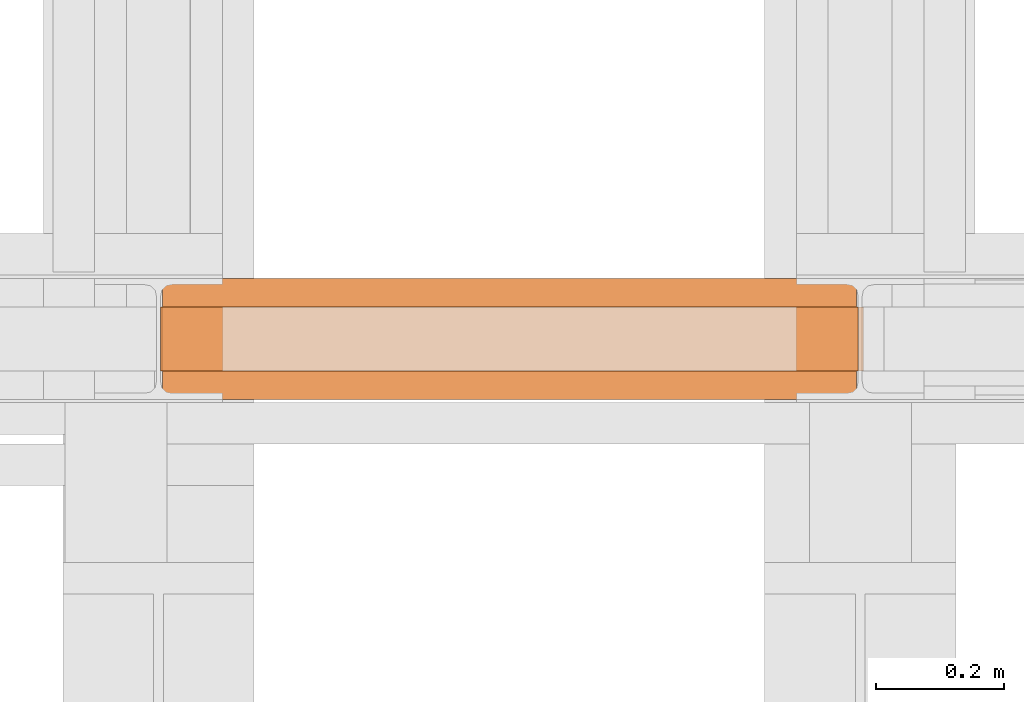
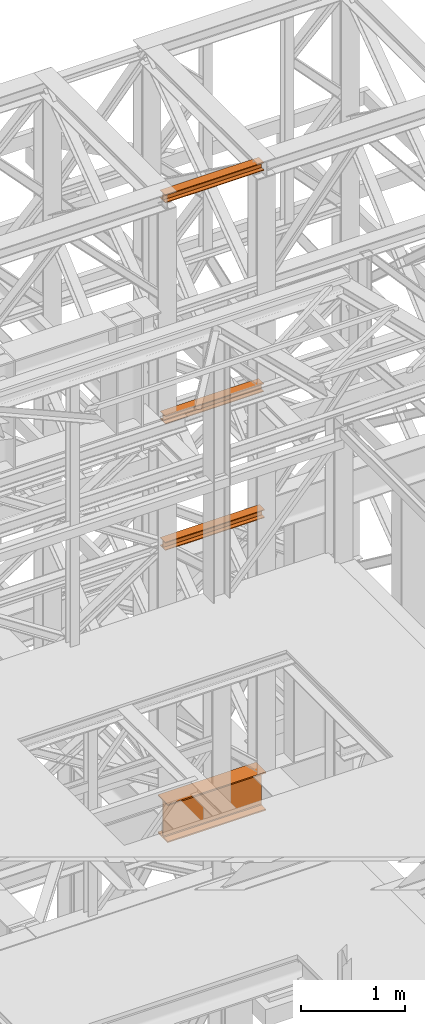
# One storey, part 152 of 208: 4 proxies.
"""IFC2X3 building model written with IfcOpenShell, lengths in millimetres."""

from ifc_helpers import new_model, entity, si_unit, converted_unit, frame, origin, origin_with_axes, place, context, subcontext, project, spatial, faceted_brep, element, save


model = new_model("IFC2X3")

# Units and contexts
model_context = context("Model", 3, precision=1e-05, world=origin())
plan_context = context("Plan", 3, precision=1e-05, world=origin())
body_context = subcontext(model_context, "Body", "Model", "MODEL_VIEW")
ifc_project = project(units=[si_unit("LENGTHUNIT", "METRE", prefix="MILLI"), converted_unit("PLANEANGLEUNIT", "DEGREE", entity("IfcPlaneAngleMeasure", 0.0174532925199433), si_unit("PLANEANGLEUNIT", "RADIAN"), dimensions=[0, 0, 0, 0, 0, 0, 0]), si_unit("AREAUNIT", "SQUARE_METRE"), si_unit("VOLUMEUNIT", "CUBIC_METRE")], contexts=[model_context, plan_context])

# Building, storey
building_placement = place(None, origin())
building = spatial("IfcBuilding", under=ifc_project, at=building_placement, CompositionType="COMPLEX")
storey_placement = place(building_placement, origin_with_axes())
storey = spatial("IfcBuildingStorey", under=building, at=storey_placement, Name="Geschoss", CompositionType="ELEMENT")

# Proxies
proxy_1_placement = place(storey_placement, frame((5499.254968580828, -16057.57439657637, 4834.989987483023), z_axis=(0.0, 0.0, 1.0), x_axis=(1.0, 0.0, 0.0)))
element("IfcBuildingElementProxy", 1, at=proxy_1_placement, inside=storey, context=body_context, shape_type="Brep", body=[
    faceted_brep([(1088.009999895696, 0.01000000000021828, 450.0100178813937), (1088.009999895696, 190.0100125169756, 450.0100178813937), (1088.009999895696, 190.0100125169756, 435.4100240564349), (1088.009999895696, 120.7100073045494, 435.4100091552737), (1088.009999895696, 109.841562265754, 433.2347078418734), (1088.009999895696, 101.8853126263621, 425.2784563398363), (1088.009999895696, 99.71000619068764, 414.4100113010409), (1088.009999895696, 99.71000619068764, 35.60999167919181), (1088.009999895696, 101.8853126263621, 24.74154664039634), (1088.009999895696, 109.841562265754, 16.78529513835929), (1088.009999895696, 120.7100073045494, 14.60999382495902), (1088.009999895696, 190.0100125169756, 14.60999382495902), (1088.009999895696, 190.0100125169756, 0.01000000000021828), (1088.009999895696, 0.01000000000021828, 0.01000000000021828), (1088.009999895696, 0.01000000000021828, 14.60999382495902), (1088.009999895696, 69.3100052124264, 14.60999382495902), (1088.009999895696, 80.17845025122188, 16.78529513835929), (1088.009999895696, 88.13469989061377, 24.74154664039634), (1088.009999895696, 90.3100063262882, 35.60999167919181), (1088.009999895696, 90.3100063262882, 414.4100113010409), (1088.009999895696, 88.13469989061377, 425.2784563398363), (1088.009999895696, 80.17845025122188, 433.2347078418734), (1088.009999895696, 69.3100052124264, 435.4100091552737), (1088.009999895696, 0.01000000000021828, 435.4100240564349), (1088.009999895696, 190.0100125169756, 450.0100178813937), (1088.009999895696, 0.01000000000021828, 450.0100178813937), (0.01000000000021828, 0.01000000000021828, 450.0100178813937), (0.01000000000021828, 190.0100125169756, 450.0100178813937), (1088.009999895696, 190.0100125169756, 435.4100240564349), (1088.009999895696, 190.0100125169756, 450.0100178813937), (0.01000000000021828, 190.0100125169756, 450.0100178813937), (0.01000000000021828, 190.0100125169756, 435.4100240564349), (1088.009999895696, 120.7100073045494, 435.4100091552737), (1088.009999895696, 190.0100125169756, 435.4100240564349), (0.01000000000021828, 190.0100125169756, 435.4100240564349), (0.01000000000021828, 120.7100073045494, 435.4100091552737), (1088.009999895696, 109.841562265754, 433.2347078418734), (1088.009999895696, 120.7100073045494, 435.4100091552737), (0.01000000000021828, 120.7100073045494, 435.4100091552737), (0.01000000000021828, 109.841562265754, 433.2347078418734), (1088.009999895696, 101.8853126263621, 425.2784563398363), (1088.009999895696, 109.841562265754, 433.2347078418734), (0.01000000000021828, 109.841562265754, 433.2347078418734), (0.01000000000021828, 101.8853126263621, 425.2784563398363), (1088.009999895696, 99.71000619068764, 414.4100113010409), (1088.009999895696, 101.8853126263621, 425.2784563398363), (0.01000000000021828, 101.8853126263621, 425.2784563398363), (0.01000000000021828, 99.71000619068764, 414.4100113010409), (1088.009999895696, 99.71000619068764, 35.60999167919181), (1088.009999895696, 99.71000619068764, 414.4100113010409), (0.01000000000021828, 99.71000619068764, 414.4100113010409), (0.01000000000021828, 99.71000619068764, 35.60999167919181), (1088.009999895696, 101.8853126263621, 24.74154664039634), (1088.009999895696, 99.71000619068764, 35.60999167919181), (0.01000000000021828, 99.71000619068764, 35.60999167919181), (0.01000000000021828, 101.8853126263621, 24.74154664039634), (1088.009999895696, 109.841562265754, 16.78529513835929), (1088.009999895696, 101.8853126263621, 24.74154664039634), (0.01000000000021828, 101.8853126263621, 24.74154664039634), (0.01000000000021828, 109.841562265754, 16.78529513835929), (1088.009999895696, 120.7100073045494, 14.60999382495902), (1088.009999895696, 109.841562265754, 16.78529513835929), (0.01000000000021828, 109.841562265754, 16.78529513835929), (0.01000000000021828, 120.7100073045494, 14.60999382495902), (1088.009999895696, 190.0100125169756, 14.60999382495902), (1088.009999895696, 120.7100073045494, 14.60999382495902), (0.01000000000021828, 120.7100073045494, 14.60999382495902), (0.01000000000021828, 190.0100125169756, 14.60999382495902), (1088.009999895696, 190.0100125169756, 0.01000000000021828), (1088.009999895696, 190.0100125169756, 14.60999382495902), (0.01000000000021828, 190.0100125169756, 14.60999382495902), (0.01000000000021828, 190.0100125169756, 0.01000000000021828), (1088.009999895696, 0.01000000000021828, 0.01000000000021828), (1088.009999895696, 190.0100125169756, 0.01000000000021828), (0.01000000000021828, 190.0100125169756, 0.01000000000021828), (0.01000000000021828, 0.01000000000021828, 0.01000000000021828), (1088.009999895696, 0.01000000000021828, 14.60999382495902), (1088.009999895696, 0.01000000000021828, 0.01000000000021828), (0.01000000000021828, 0.01000000000021828, 0.01000000000021828), (0.01000000000021828, 0.01000000000021828, 14.60999382495902), (1088.009999895696, 69.3100052124264, 14.60999382495902), (1088.009999895696, 0.01000000000021828, 14.60999382495902), (0.01000000000021828, 0.01000000000021828, 14.60999382495902), (0.01000000000021828, 69.3100052124264, 14.60999382495902), (1088.009999895696, 80.17845025122188, 16.78529513835929), (1088.009999895696, 69.3100052124264, 14.60999382495902), (0.01000000000021828, 69.3100052124264, 14.60999382495902), (0.01000000000021828, 80.17845025122188, 16.78529513835929), (1088.009999895696, 88.13469989061377, 24.74154664039634), (1088.009999895696, 80.17845025122188, 16.78529513835929), (0.01000000000021828, 80.17845025122188, 16.78529513835929), (0.01000000000021828, 88.13469989061377, 24.74154664039634), (1088.009999895696, 90.3100063262882, 35.60999167919181), (1088.009999895696, 88.13469989061377, 24.74154664039634), (0.01000000000021828, 88.13469989061377, 24.74154664039634), (0.01000000000021828, 90.3100063262882, 35.60999167919181), (1088.009999895696, 90.3100063262882, 414.4100113010409), (1088.009999895696, 90.3100063262882, 35.60999167919181), (0.01000000000021828, 90.3100063262882, 35.60999167919181), (0.01000000000021828, 90.3100063262882, 414.4100113010409), (1088.009999895696, 88.13469989061377, 425.2784563398363), (1088.009999895696, 90.3100063262882, 414.4100113010409), (0.01000000000021828, 90.3100063262882, 414.4100113010409), (0.01000000000021828, 88.13469989061377, 425.2784563398363), (1088.009999895696, 80.17845025122188, 433.2347078418734), (1088.009999895696, 88.13469989061377, 425.2784563398363), (0.01000000000021828, 88.13469989061377, 425.2784563398363), (0.01000000000021828, 80.17845025122188, 433.2347078418734), (1088.009999895696, 69.3100052124264, 435.4100091552737), (1088.009999895696, 80.17845025122188, 433.2347078418734), (0.01000000000021828, 80.17845025122188, 433.2347078418734), (0.01000000000021828, 69.3100052124264, 435.4100091552737), (1088.009999895696, 0.01000000000021828, 435.4100240564349), (1088.009999895696, 69.3100052124264, 435.4100091552737), (0.01000000000021828, 69.3100052124264, 435.4100091552737), (0.01000000000021828, 0.01000000000021828, 435.4100240564349), (1088.009999895696, 0.01000000000021828, 450.0100178813937), (1088.009999895696, 0.01000000000021828, 435.4100240564349), (0.01000000000021828, 0.01000000000021828, 435.4100240564349), (0.01000000000021828, 0.01000000000021828, 450.0100178813937), (0.01000000000021828, 0.01000000000021828, 450.0100178813937), (0.01000000000021828, 0.01000000000021828, 435.4100240564349), (0.01000000000021828, 69.3100052124264, 435.4100091552737), (0.01000000000021828, 80.17845025122188, 433.2347078418734), (0.01000000000021828, 88.13469989061377, 425.2784563398363), (0.01000000000021828, 90.3100063262882, 414.4100113010409), (0.01000000000021828, 90.3100063262882, 35.60999167919181), (0.01000000000021828, 88.13469989061377, 24.74154664039634), (0.01000000000021828, 80.17845025122188, 16.78529513835929), (0.01000000000021828, 69.3100052124264, 14.60999382495902), (0.01000000000021828, 0.01000000000021828, 14.60999382495902), (0.01000000000021828, 0.01000000000021828, 0.01000000000021828), (0.01000000000021828, 190.0100125169756, 0.01000000000021828), (0.01000000000021828, 190.0100125169756, 14.60999382495902), (0.01000000000021828, 120.7100073045494, 14.60999382495902), (0.01000000000021828, 109.841562265754, 16.78529513835929), (0.01000000000021828, 101.8853126263621, 24.74154664039634), (0.01000000000021828, 99.71000619068764, 35.60999167919181), (0.01000000000021828, 99.71000619068764, 414.4100113010409), (0.01000000000021828, 101.8853126263621, 425.2784563398363), (0.01000000000021828, 109.841562265754, 433.2347078418734), (0.01000000000021828, 120.7100073045494, 435.4100091552737), (0.01000000000021828, 190.0100125169756, 435.4100240564349), (0.01000000000021828, 190.0100125169756, 450.0100178813937)], [[[0, 1, 2, 3, 4, 5, 6, 7, 8, 9, 10, 11, 12, 13, 14, 15, 16, 17, 18, 19, 20, 21, 22, 23]], [[24, 25, 26, 27]], [[28, 29, 30, 31]], [[32, 33, 34, 35]], [[36, 37, 38, 39]], [[40, 41, 42, 43]], [[44, 45, 46, 47]], [[48, 49, 50, 51]], [[52, 53, 54, 55]], [[56, 57, 58, 59]], [[60, 61, 62, 63]], [[64, 65, 66, 67]], [[68, 69, 70, 71]], [[72, 73, 74, 75]], [[76, 77, 78, 79]], [[80, 81, 82, 83]], [[84, 85, 86, 87]], [[88, 89, 90, 91]], [[92, 93, 94, 95]], [[96, 97, 98, 99]], [[100, 101, 102, 103]], [[104, 105, 106, 107]], [[108, 109, 110, 111]], [[112, 113, 114, 115]], [[116, 117, 118, 119]], [[120, 121, 122, 123, 124, 125, 126, 127, 128, 129, 130, 131, 132, 133, 134, 135, 136, 137, 138, 139, 140, 141, 142, 143]]], orient=[[False], [False], [False], [False], [False], [False], [False], [False], [False], [False], [False], [False], [False], [False], [False], [False], [False], [False], [False], [False], [False], [False], [False], [False], [False], [False]]),
])
proxy_2_placement = place(storey_placement, frame((5498.369516902634, -16012.50587051043, 9710.10571322234), z_axis=(0.0, 0.0, 1.0), x_axis=(1.0, 0.0, 0.0)))
element("IfcBuildingElementProxy", 2, at=proxy_2_placement, inside=storey, context=body_context, shape_type="Brep", body=[
    faceted_brep([(1091.936120735611, 0.01000000000021828, 88.01000000000022), (1091.936120735611, 0.01000000000021828, 96.01000000000022), (1091.936120735611, 100.0100000000002, 96.01000000000022), (1091.936120735611, 100.0100000000002, 88.01000000000022), (1091.936120735611, 52.51000000000022, 88.01000000000022), (1091.936120735611, 52.51000000000022, 8.010000000000218), (1091.936120735611, 100.0100000000002, 8.010000000000218), (1091.936120735611, 100.0100000000002, 0.01000000000021828), (1091.936120735611, 0.01000000000021828, 0.01000000000021828), (1091.936120735611, 0.01000000000021828, 8.010000000000218), (1091.936120735611, 47.51000000000022, 8.010000000000218), (1091.936120735611, 47.51000000000022, 88.01000000000022), (1091.936120735611, 0.01000000000021828, 96.01000000000022), (1091.936120735611, 0.01000000000021828, 88.01000000000022), (0.009999999999308784, 0.01000000000385626, 88.01000000000022), (0.009999999999308784, 0.01000000000385626, 96.01000000000022), (1091.936120735611, 100.0100000000002, 96.01000000000022), (1091.936120735611, 0.01000000000021828, 96.01000000000022), (0.009999999999308784, 0.01000000000385626, 96.01000000000022), (0.009999999999308784, 100.0100000000039, 96.01000000000022), (1091.936120735611, 100.0100000000002, 88.01000000000022), (1091.936120735611, 100.0100000000002, 96.01000000000022), (0.009999999999308784, 100.0100000000039, 96.01000000000022), (0.009999999999308784, 100.0100000000039, 88.01000000000022), (1091.936120735611, 52.51000000000022, 88.01000000000022), (1091.936120735611, 100.0100000000002, 88.01000000000022), (0.009999999999308784, 100.0100000000039, 88.01000000000022), (0.009999999999308784, 52.51000000000386, 88.01000000000022), (1091.936120735611, 52.51000000000022, 8.010000000000218), (1091.936120735611, 52.51000000000022, 88.01000000000022), (0.009999999999308784, 52.51000000000386, 88.01000000000022), (0.009999999999308784, 52.51000000000386, 8.010000000000218), (1091.936120735611, 100.0100000000002, 8.010000000000218), (1091.936120735611, 52.51000000000022, 8.010000000000218), (0.009999999999308784, 52.51000000000386, 8.010000000000218), (0.009999999999308784, 100.0100000000039, 8.010000000000218), (1091.936120735611, 100.0100000000002, 0.01000000000021828), (1091.936120735611, 100.0100000000002, 8.010000000000218), (0.009999999999308784, 100.0100000000039, 8.010000000000218), (0.009999999999308784, 100.0100000000039, 0.01000000000021828), (1091.936120735611, 0.01000000000021828, 0.01000000000021828), (1091.936120735611, 100.0100000000002, 0.01000000000021828), (0.009999999999308784, 100.0100000000039, 0.01000000000021828), (0.009999999999308784, 0.01000000000385626, 0.01000000000021828), (1091.936120735611, 0.01000000000021828, 8.010000000000218), (1091.936120735611, 0.01000000000021828, 0.01000000000021828), (0.009999999999308784, 0.01000000000385626, 0.01000000000021828), (0.009999999999308784, 0.01000000000385626, 8.010000000000218), (1091.936120735611, 47.51000000000022, 8.010000000000218), (1091.936120735611, 0.01000000000021828, 8.010000000000218), (0.009999999999308784, 0.01000000000385626, 8.010000000000218), (0.009999999999308784, 47.51000000000386, 8.010000000000218), (1091.936120735611, 47.51000000000022, 88.01000000000022), (1091.936120735611, 47.51000000000022, 8.010000000000218), (0.009999999999308784, 47.51000000000386, 8.010000000000218), (0.009999999999308784, 47.51000000000386, 88.01000000000022), (1091.936120735611, 0.01000000000021828, 88.01000000000022), (1091.936120735611, 47.51000000000022, 88.01000000000022), (0.009999999999308784, 47.51000000000386, 88.01000000000022), (0.009999999999308784, 0.01000000000385626, 88.01000000000022), (0.009999999999308784, 0.01000000000385626, 88.01000000000022), (0.009999999999308784, 47.51000000000386, 88.01000000000022), (0.009999999999308784, 47.51000000000386, 8.010000000000218), (0.009999999999308784, 0.01000000000385626, 8.010000000000218), (0.009999999999308784, 0.01000000000385626, 0.01000000000021828), (0.009999999999308784, 100.0100000000039, 0.01000000000021828), (0.009999999999308784, 100.0100000000039, 8.010000000000218), (0.009999999999308784, 52.51000000000386, 8.010000000000218), (0.009999999999308784, 52.51000000000386, 88.01000000000022), (0.009999999999308784, 100.0100000000039, 88.01000000000022), (0.009999999999308784, 100.0100000000039, 96.01000000000022), (0.009999999999308784, 0.01000000000385626, 96.01000000000022)], [[[0, 1, 2, 3, 4, 5, 6, 7, 8, 9, 10, 11]], [[12, 13, 14, 15]], [[16, 17, 18, 19]], [[20, 21, 22, 23]], [[24, 25, 26, 27]], [[28, 29, 30, 31]], [[32, 33, 34, 35]], [[36, 37, 38, 39]], [[40, 41, 42, 43]], [[44, 45, 46, 47]], [[48, 49, 50, 51]], [[52, 53, 54, 55]], [[56, 57, 58, 59]], [[60, 61, 62, 63, 64, 65, 66, 67, 68, 69, 70, 71]]], orient=[[False], [False], [False], [False], [False], [False], [False], [False], [False], [False], [False], [False], [False], [False]]),
])
proxy_3_placement = place(storey_placement, frame((5496.504968595721, -16012.50587051043, 12300.47045114381), z_axis=(0.0, 0.0, 1.0), x_axis=(1.0, 0.0, 0.0)))
element("IfcBuildingElementProxy", 3, at=proxy_3_placement, inside=storey, context=body_context, shape_type="Brep", body=[
    faceted_brep([(1093.509999865889, 0.01000000000021828, 88.01000000000022), (1093.509999865889, 0.01000000000021828, 96.01000000000022), (1093.509999865889, 100.0100000000002, 96.01000000000022), (1093.509999865889, 100.0100000000002, 88.01000000000022), (1093.509999865889, 52.51000000000022, 88.01000000000022), (1093.509999865889, 52.51000000000022, 8.010000000000218), (1093.509999865889, 100.0100000000002, 8.010000000000218), (1093.509999865889, 100.0100000000002, 0.01000000000021828), (1093.509999865889, 0.01000000000021828, 0.01000000000021828), (1093.509999865889, 0.01000000000021828, 8.010000000000218), (1093.509999865889, 47.51000000000022, 8.010000000000218), (1093.509999865889, 47.51000000000022, 88.01000000000022), (1093.509999865889, 0.01000000000021828, 96.01000000000022), (1093.509999865889, 0.01000000000021828, 88.01000000000022), (0.01000000000021828, 0.01000000000385626, 88.01000000000022), (0.01000000000021828, 0.01000000000385626, 96.01000000000022), (1093.509999865889, 100.0100000000002, 96.01000000000022), (1093.509999865889, 0.01000000000021828, 96.01000000000022), (0.01000000000021828, 0.01000000000385626, 96.01000000000022), (0.01000000000021828, 100.0100000000039, 96.01000000000022), (1093.509999865889, 100.0100000000002, 88.01000000000022), (1093.509999865889, 100.0100000000002, 96.01000000000022), (0.01000000000021828, 100.0100000000039, 96.01000000000022), (0.01000000000021828, 100.0100000000039, 88.01000000000022), (1093.509999865889, 52.51000000000022, 88.01000000000022), (1093.509999865889, 100.0100000000002, 88.01000000000022), (0.01000000000021828, 100.0100000000039, 88.01000000000022), (0.01000000000021828, 52.51000000000386, 88.01000000000022), (1093.509999865889, 52.51000000000022, 8.010000000000218), (1093.509999865889, 52.51000000000022, 88.01000000000022), (0.01000000000021828, 52.51000000000386, 88.01000000000022), (0.01000000000021828, 52.51000000000386, 8.010000000000218), (1093.509999865889, 100.0100000000002, 8.010000000000218), (1093.509999865889, 52.51000000000022, 8.010000000000218), (0.01000000000021828, 52.51000000000386, 8.010000000000218), (0.01000000000021828, 100.0100000000039, 8.010000000000218), (1093.509999865889, 100.0100000000002, 0.01000000000021828), (1093.509999865889, 100.0100000000002, 8.010000000000218), (0.01000000000021828, 100.0100000000039, 8.010000000000218), (0.01000000000021828, 100.0100000000039, 0.01000000000021828), (1093.509999865889, 0.01000000000021828, 0.01000000000021828), (1093.509999865889, 100.0100000000002, 0.01000000000021828), (0.01000000000021828, 100.0100000000039, 0.01000000000021828), (0.01000000000021828, 0.01000000000385626, 0.01000000000021828), (1093.509999865889, 0.01000000000021828, 8.010000000000218), (1093.509999865889, 0.01000000000021828, 0.01000000000021828), (0.01000000000021828, 0.01000000000385626, 0.01000000000021828), (0.01000000000021828, 0.01000000000385626, 8.010000000000218), (1093.509999865889, 47.51000000000022, 8.010000000000218), (1093.509999865889, 0.01000000000021828, 8.010000000000218), (0.01000000000021828, 0.01000000000385626, 8.010000000000218), (0.01000000000021828, 47.51000000000386, 8.010000000000218), (1093.509999865889, 47.51000000000022, 88.01000000000022), (1093.509999865889, 47.51000000000022, 8.010000000000218), (0.01000000000021828, 47.51000000000386, 8.010000000000218), (0.01000000000021828, 47.51000000000386, 88.01000000000022), (1093.509999865889, 0.01000000000021828, 88.01000000000022), (1093.509999865889, 47.51000000000022, 88.01000000000022), (0.01000000000021828, 47.51000000000386, 88.01000000000022), (0.01000000000021828, 0.01000000000385626, 88.01000000000022), (0.01000000000021828, 0.01000000000385626, 88.01000000000022), (0.01000000000021828, 47.51000000000386, 88.01000000000022), (0.01000000000021828, 47.51000000000386, 8.010000000000218), (0.01000000000021828, 0.01000000000385626, 8.010000000000218), (0.01000000000021828, 0.01000000000385626, 0.01000000000021828), (0.01000000000021828, 100.0100000000039, 0.01000000000021828), (0.01000000000021828, 100.0100000000039, 8.010000000000218), (0.01000000000021828, 52.51000000000386, 8.010000000000218), (0.01000000000021828, 52.51000000000386, 88.01000000000022), (0.01000000000021828, 100.0100000000039, 88.01000000000022), (0.01000000000021828, 100.0100000000039, 96.01000000000022), (0.01000000000021828, 0.01000000000385626, 96.01000000000022)], [[[0, 1, 2, 3, 4, 5, 6, 7, 8, 9, 10, 11]], [[12, 13, 14, 15]], [[16, 17, 18, 19]], [[20, 21, 22, 23]], [[24, 25, 26, 27]], [[28, 29, 30, 31]], [[32, 33, 34, 35]], [[36, 37, 38, 39]], [[40, 41, 42, 43]], [[44, 45, 46, 47]], [[48, 49, 50, 51]], [[52, 53, 54, 55]], [[56, 57, 58, 59]], [[60, 61, 62, 63, 64, 65, 66, 67, 68, 69, 70, 71]]], orient=[[False], [False], [False], [False], [False], [False], [False], [False], [False], [False], [False], [False], [False], [False]]),
])
proxy_4_placement = place(storey_placement, frame((5496.504968595723, -16012.50587051043, 8230.356417081653), z_axis=(0.0, 0.0, 1.0), x_axis=(1.0, 0.0, 0.0)))
element("IfcBuildingElementProxy", 4, at=proxy_4_placement, inside=storey, context=body_context, shape_type="Brep", body=[
    faceted_brep([(1101.874548306911, 0.01000000000021828, 88.01000000000022), (1101.874548306911, 0.01000000000021828, 96.01000000000022), (1101.874548306911, 100.0100000000002, 96.01000000000022), (1101.874548306911, 100.0100000000002, 88.01000000000022), (1101.874548306911, 52.51000000000022, 88.01000000000022), (1101.874548306911, 52.51000000000022, 8.010000000000218), (1101.874548306911, 100.0100000000002, 8.010000000000218), (1101.874548306911, 100.0100000000002, 0.01000000000021828), (1101.874548306911, 0.01000000000021828, 0.01000000000021828), (1101.874548306911, 0.01000000000021828, 8.010000000000218), (1101.874548306911, 47.51000000000022, 8.010000000000218), (1101.874548306911, 47.51000000000022, 88.01000000000022), (1101.874548306911, 0.01000000000021828, 96.01000000000022), (1101.874548306911, 0.01000000000021828, 88.01000000000022), (0.009999999999308784, 0.01000000000385626, 88.01000000000022), (0.009999999999308784, 0.01000000000385626, 96.01000000000022), (1101.874548306911, 100.0100000000002, 96.01000000000022), (1101.874548306911, 0.01000000000021828, 96.01000000000022), (0.009999999999308784, 0.01000000000385626, 96.01000000000022), (0.009999999999308784, 100.0100000000039, 96.01000000000022), (1101.874548306911, 100.0100000000002, 88.01000000000022), (1101.874548306911, 100.0100000000002, 96.01000000000022), (0.009999999999308784, 100.0100000000039, 96.01000000000022), (0.009999999999308784, 100.0100000000039, 88.01000000000022), (1101.874548306911, 52.51000000000022, 88.01000000000022), (1101.874548306911, 100.0100000000002, 88.01000000000022), (0.009999999999308784, 100.0100000000039, 88.01000000000022), (0.009999999999308784, 52.51000000000386, 88.01000000000022), (1101.874548306911, 52.51000000000022, 8.010000000000218), (1101.874548306911, 52.51000000000022, 88.01000000000022), (0.009999999999308784, 52.51000000000386, 88.01000000000022), (0.009999999999308784, 52.51000000000386, 8.010000000000218), (1101.874548306911, 100.0100000000002, 8.010000000000218), (1101.874548306911, 52.51000000000022, 8.010000000000218), (0.009999999999308784, 52.51000000000386, 8.010000000000218), (0.009999999999308784, 100.0100000000039, 8.010000000000218), (1101.874548306911, 100.0100000000002, 0.01000000000021828), (1101.874548306911, 100.0100000000002, 8.010000000000218), (0.009999999999308784, 100.0100000000039, 8.010000000000218), (0.009999999999308784, 100.0100000000039, 0.01000000000021828), (1101.874548306911, 0.01000000000021828, 0.01000000000021828), (1101.874548306911, 100.0100000000002, 0.01000000000021828), (0.009999999999308784, 100.0100000000039, 0.01000000000021828), (0.009999999999308784, 0.01000000000385626, 0.01000000000021828), (1101.874548306911, 0.01000000000021828, 8.010000000000218), (1101.874548306911, 0.01000000000021828, 0.01000000000021828), (0.009999999999308784, 0.01000000000385626, 0.01000000000021828), (0.009999999999308784, 0.01000000000385626, 8.010000000000218), (1101.874548306911, 47.51000000000022, 8.010000000000218), (1101.874548306911, 0.01000000000021828, 8.010000000000218), (0.009999999999308784, 0.01000000000385626, 8.010000000000218), (0.009999999999308784, 47.51000000000386, 8.010000000000218), (1101.874548306911, 47.51000000000022, 88.01000000000022), (1101.874548306911, 47.51000000000022, 8.010000000000218), (0.009999999999308784, 47.51000000000386, 8.010000000000218), (0.009999999999308784, 47.51000000000386, 88.01000000000022), (1101.874548306911, 0.01000000000021828, 88.01000000000022), (1101.874548306911, 47.51000000000022, 88.01000000000022), (0.009999999999308784, 47.51000000000386, 88.01000000000022), (0.009999999999308784, 0.01000000000385626, 88.01000000000022), (0.009999999999308784, 0.01000000000385626, 88.01000000000022), (0.009999999999308784, 47.51000000000386, 88.01000000000022), (0.009999999999308784, 47.51000000000386, 8.010000000000218), (0.009999999999308784, 0.01000000000385626, 8.010000000000218), (0.009999999999308784, 0.01000000000385626, 0.01000000000021828), (0.009999999999308784, 100.0100000000039, 0.01000000000021828), (0.009999999999308784, 100.0100000000039, 8.010000000000218), (0.009999999999308784, 52.51000000000386, 8.010000000000218), (0.009999999999308784, 52.51000000000386, 88.01000000000022), (0.009999999999308784, 100.0100000000039, 88.01000000000022), (0.009999999999308784, 100.0100000000039, 96.01000000000022), (0.009999999999308784, 0.01000000000385626, 96.01000000000022)], [[[0, 1, 2, 3, 4, 5, 6, 7, 8, 9, 10, 11]], [[12, 13, 14, 15]], [[16, 17, 18, 19]], [[20, 21, 22, 23]], [[24, 25, 26, 27]], [[28, 29, 30, 31]], [[32, 33, 34, 35]], [[36, 37, 38, 39]], [[40, 41, 42, 43]], [[44, 45, 46, 47]], [[48, 49, 50, 51]], [[52, 53, 54, 55]], [[56, 57, 58, 59]], [[60, 61, 62, 63, 64, 65, 66, 67, 68, 69, 70, 71]]], orient=[[False], [False], [False], [False], [False], [False], [False], [False], [False], [False], [False], [False], [False], [False]]),
])

save(model, "model.ifc")
